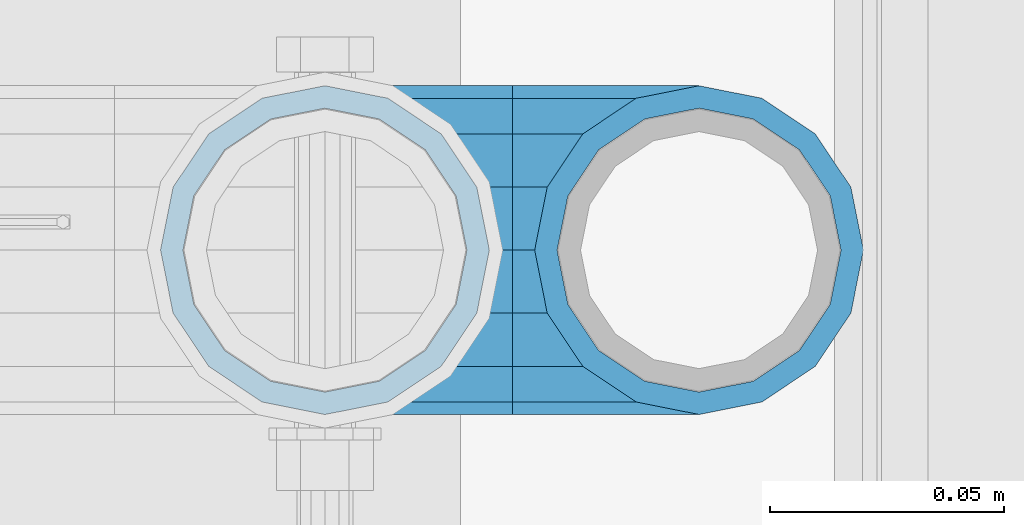
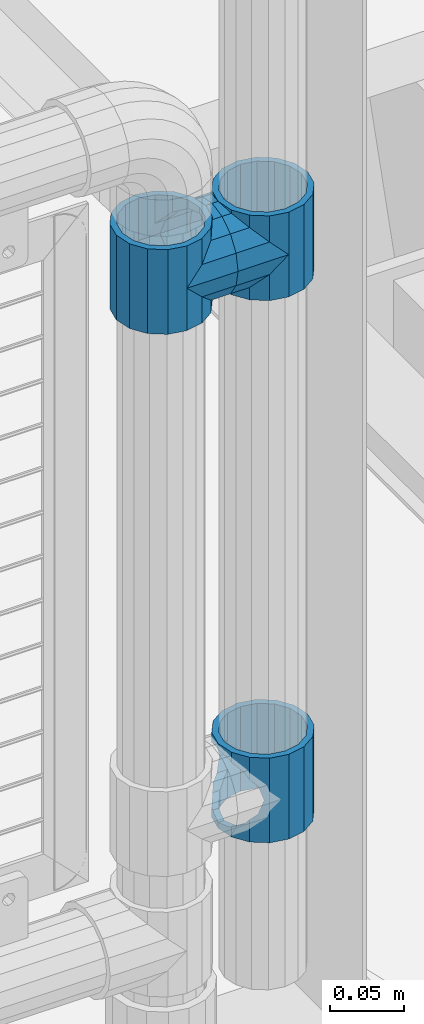
# One storey, part 163 of 240: 5 beams.
"""IFC2X3 building model written with IfcOpenShell, lengths in millimetres."""

from ifc_helpers import new_model, si_unit, frame, origin_with_axes, place, context, subcontext, project, spatial, faceted_brep, material, type_object, element, save


model = new_model("IFC2X3")

# Units and contexts
model_context = context("Model", 3, precision=1e-05, world=origin_with_axes())
body_context = subcontext(model_context, "Body", "Model", "MODEL_VIEW")
ifc_project = project(units=[si_unit("LENGTHUNIT", "METRE", prefix="MILLI"), si_unit("AREAUNIT", "SQUARE_METRE"), si_unit("VOLUMEUNIT", "CUBIC_METRE"), si_unit("MASSUNIT", "GRAM", prefix="KILO"), si_unit("TIMEUNIT", "SECOND"), si_unit("PLANEANGLEUNIT", "RADIAN"), si_unit("SOLIDANGLEUNIT", "STERADIAN"), si_unit("THERMODYNAMICTEMPERATUREUNIT", "DEGREE_CELSIUS"), si_unit("LUMINOUSINTENSITYUNIT", "LUMEN")], contexts=[model_context])

# Site, building, storey
site_placement = place(None, origin_with_axes())
site = spatial("IfcSite", under=ifc_project, at=site_placement, CompositionType="ELEMENT")
building_placement = place(site_placement, origin_with_axes())
building = spatial("IfcBuilding", under=site, at=building_placement, Name="Standard", CompositionType="ELEMENT")
storey_placement = place(building_placement, origin_with_axes())
storey = spatial("IfcBuildingStorey", under=building, at=storey_placement, Name="Undefined", CompositionType="ELEMENT", Elevation=0.0)

# Beams
ifc_material = material(Name="Misc_Undefined")
beam_type = type_object("IfcBeamType", PredefinedType="NOTDEFINED")
beam_1_placement = place(storey_placement, frame((55961.0, 34664.5, 433.819999999999), z_axis=(1.0, 0.0, 0.0), x_axis=(0.0, 0.0, -1.0)))
element("IfcBeam", 1, at=beam_1_placement, inside=storey, type_object=beam_type, material=ifc_material, context=body_context, shape_type="Brep", body=[
    faceted_brep([(46.7644421722801, 28.0397438117143, -11.6144421722784), (46.7644421722801, 28.0397438117143, -20.0882031229849), (51.5310424079941, 24.8548033587067, -24.8548033587067), (56.6106908090114, 21.4606908090136, -27.1226768591077), (56.6106908090114, 21.4606908090136, -21.4606908090136), (61.9623795176703, 13.4513226476338, -32.4743655677739), (63.1897438117172, 11.6144421722784, -32.8397438117172), (63.1897438117172, 11.6144421722784, -28.0397438117143), (65.4999999999997, 0.0, -35.1500000000015), (65.4999999999997, 0.0, -30.3499999999985), (63.1897438117172, -11.6144421722784, -32.8397438117245), (63.1897438117172, -11.6144421722784, -28.0397438117143), (61.9623795176703, -13.4513226476338, -32.4743655677739), (56.6106908090114, -21.4606908090136, -27.1226768591223), (56.6106908090114, -21.4606908090136, -21.4606908090136), (51.5310424080006, -24.8548033587067, -24.8548033587067), (46.7644421722801, -28.0397438117143, -20.0882031229994), (46.7644421722801, -28.0397438117143, -11.6144421722784), (35.1499999999996, -30.3499999999985, -16.6306603983758), (35.1500000000015, -30.35, 0.0), (23.5355578277191, -28.0397438117143, -20.0882031229994), (23.5355578277191, -28.0397438117143, -11.6144421722784), (18.7689575919987, -24.8548033587067, -24.8548033587067), (13.6893091909879, -21.4606908090136, -27.1226768591223), (13.6893091909879, -21.4606908090136, -21.4606908090136), (8.33762048232455, -13.4513226476338, -32.4743655677739), (7.11025618828211, -11.6144421722784, -32.8397438117245), (7.11025618828211, -11.6144421722784, -28.0397438117143), (4.79999999999961, 0.0, -35.1500000000015), (4.79999999999961, 0.0, -30.3499999999985), (7.11025618828211, 11.6144421722784, -32.8397438117172), (7.11025618828211, 11.6144421722784, -28.0397438117143), (8.33762048232893, 13.4513226476338, -32.4743655677739), (13.6893091909879, 21.4606908090136, -27.1226768591077), (13.6893091909879, 21.4606908090136, -21.4606908090136), (18.7689575919921, 24.8548033587067, -24.8548033587067), (23.5355578277192, 28.0397438117143, -20.0882031229849), (23.5355578277192, 28.0397438117143, -11.6144421722784), (35.1499999999996, 30.3499999999985, -16.6306603983685), (35.1500000000015, 30.35, 0.0), (0.0, 32.4743655677739, -13.4513226476338), (0.0, 35.1500000000015, 0.0), (70.2999999999993, 35.1500000000015, 0.0), (70.2999999999993, 32.4743655677739, -13.4513226476338), (0.0, 32.4743655677739, 13.4513226476338), (70.2999999999993, 32.4743655677739, 13.4513226476338), (0.0, 24.8548033587067, 24.8548033587067), (70.2999999999993, 24.8548033587067, 24.8548033587067), (0.0, 13.4513226476338, 32.4743655677739), (70.2999999999993, 13.4513226476338, 32.4743655677739), (0.0, 0.0, 35.1500000000015), (70.2999999999993, 0.0, 35.1500000000015), (0.0, -13.4513226476338, 32.4743655677739), (70.2999999999993, -13.4513226476338, 32.4743655677739), (0.0, -24.8548033587067, 24.8548033587067), (70.2999999999993, -24.8548033587067, 24.8548033587067), (0.0, -32.4743655677739, 13.4513226476338), (70.2999999999993, -32.4743655677739, 13.4513226476338), (0.0, -35.1500000000015, 0.0), (70.2999999999993, -35.1500000000015, 0.0), (70.2999999999993, -30.3499999999985, 0.0), (70.2999999999993, -28.0397438117143, -11.6144421722784), (70.2999999999993, -21.4606908090136, -21.4606908090136), (70.2999999999993, -11.6144421722784, -28.0397438117143), (70.2999999999993, 0.0, -30.3499999999985), (70.2999999999993, 11.6144421722784, -28.0397438117143), (70.2999999999993, 21.4606908090136, -21.4606908090136), (70.2999999999993, 28.0397438117143, -11.6144421722784), (0.0, -28.0397438117143, -11.6144421722784), (0.0, -30.3499999999985, 0.0), (0.0, -21.4606908090136, -21.4606908090136), (0.0, -11.6144421722784, -28.0397438117143), (0.0, 0.0, -30.3499999999985), (0.0, 11.6144421722784, -28.0397438117143), (0.0, 21.4606908090136, -21.4606908090136), (0.0, 28.0397438117143, -11.6144421722784), (0.0, 30.3499999999985, 0.0), (70.2999999999993, 30.3499999999985, 0.0), (0.0, 28.0397438117143, 11.6144421722784), (70.2999999999993, 28.0397438117143, 11.6144421722784), (0.0, 21.4606908090136, 21.4606908090136), (70.2999999999993, 21.4606908090136, 21.4606908090136), (0.0, 11.6144421722784, 28.0397438117143), (70.2999999999993, 11.6144421722784, 28.0397438117143), (0.0, 0.0, 30.3499999999985), (70.2999999999993, 0.0, 30.3499999999985), (0.0, -11.6144421722784, 28.0397438117143), (70.2999999999993, -11.6144421722784, 28.0397438117143), (0.0, -21.4606908090136, 21.4606908090136), (70.2999999999993, -21.4606908090136, 21.4606908090136), (0.0, -28.0397438117143, 11.6144421722784), (70.2999999999993, -28.0397438117143, 11.6144421722784), (70.2999999999993, -24.8548033587067, -24.8548033587067), (70.2999999999993, -13.4513226476338, -32.4743655677739), (70.2999999999993, 0.0, -35.1500000000015), (70.2999999999993, 13.4513226476338, -32.4743655677739), (70.2999999999993, 24.8548033587067, -24.8548033587067), (70.2999999999993, -32.4743655677739, -13.4513226476338), (0.0, -32.4743655677739, -13.4513226476338), (0.0, 24.8548033587067, -24.8548033587067), (0.0, 13.4513226476338, -32.4743655677739), (0.0, 0.0, -35.1500000000015), (0.0, -13.4513226476338, -32.4743655677739), (0.0, -24.8548033587067, -24.8548033587067)], [[[0, 1, 2, 3, 4]], [[4, 3, 5, 6, 7]], [[7, 6, 8, 9]], [[9, 8, 10, 11]], [[11, 10, 12, 13, 14]], [[14, 13, 15, 16, 17]], [[17, 16, 18, 19]], [[19, 18, 20, 21]], [[21, 20, 22, 23, 24]], [[24, 23, 25, 26, 27]], [[27, 26, 28, 29]], [[29, 28, 30, 31]], [[31, 30, 32, 33, 34]], [[34, 33, 35, 36, 37]], [[37, 36, 38, 39]], [[39, 38, 1, 0]], [[40, 41, 42, 43]], [[41, 44, 45, 42]], [[44, 46, 47, 45]], [[46, 48, 49, 47]], [[48, 50, 51, 49]], [[50, 52, 53, 51]], [[52, 54, 55, 53]], [[54, 56, 57, 55]], [[56, 58, 59, 57]], [[60, 61, 17, 19]], [[61, 62, 14, 17]], [[62, 63, 11, 14]], [[63, 64, 9, 11]], [[64, 65, 7, 9]], [[65, 66, 4, 7]], [[66, 67, 0, 4]], [[68, 69, 19, 21]], [[70, 68, 21, 24]], [[71, 70, 24, 27]], [[72, 71, 27, 29]], [[73, 72, 29, 31]], [[74, 73, 31, 34]], [[75, 74, 34, 37]], [[76, 75, 37, 39]], [[67, 77, 39, 0]], [[78, 76, 39, 77, 79]], [[80, 78, 79, 81]], [[82, 80, 81, 83]], [[84, 82, 83, 85]], [[86, 84, 85, 87]], [[88, 86, 87, 89]], [[90, 88, 89, 91]], [[19, 69, 90, 91, 60]], [[92, 93, 94, 95, 96, 43, 42, 45, 47, 49, 51, 53, 55, 57, 59, 97], [89, 87, 85, 83, 81, 79, 77, 67, 66, 65, 64, 63, 62, 61, 60, 91]], [[58, 98, 97, 59]], [[56, 54, 52, 50, 48, 46, 44, 41, 40, 99, 100, 101, 102, 103, 98, 58], [68, 70, 71, 72, 73, 74, 75, 76, 78, 80, 82, 84, 86, 88, 90, 69]], [[32, 100, 99, 35, 33]], [[28, 101, 100, 32, 30]], [[102, 101, 28, 26, 25]], [[103, 102, 25, 23, 22]], [[15, 92, 97, 98, 103, 22, 20, 18, 16]], [[12, 93, 92, 15, 13]], [[8, 94, 93, 12, 10]], [[95, 94, 8, 6, 5]], [[96, 95, 5, 3, 2]], [[35, 99, 40, 43, 96, 2, 1, 38, 36]]]),
])
beam_2_placement = place(storey_placement, frame((55881.0, 34664.5, 848.669999999998), z_axis=(0.0, -1.0, 0.0), x_axis=(1.0, 0.0, 0.0)))
element("IfcBeam", 2, at=beam_2_placement, inside=storey, type_object=beam_type, material=ifc_material, context=body_context, shape_type="Brep", body=[
    faceted_brep([(0.0, 0.0, -35.1500000000015), (13.4513226476338, -13.4513226476329, -32.4743655677739), (13.4513226476338, 13.4513226476329, -32.4743655677739), (32.4743655677739, 32.4743655677717, 13.4513226476338), (32.4743655677739, 26.8123795176755, 13.4513226476338), (27.1226768591005, 21.4606908090117, 21.4606908090136), (24.8548033587067, 16.3810424080013, 24.8548033587067), (24.8548033587067, 24.8548033587072, 24.8548033587067), (0.0, 0.0, 35.1500000000015), (13.4513226476338, 13.4513226476329, 32.4743655677739), (13.4513226476338, -13.4513226476329, 32.4743655677739), (20.0882031229849, 11.6144421722805, 28.0397438117143), (16.6306603983685, 0.0, 30.3499999999985), (20.0882031229849, -11.6144421722805, 28.0397438117143), (24.8548033587067, -16.3810424080078, 24.8548033587067), (24.8548033587067, -24.8548033587072, 24.8548033587067), (27.1226768591005, -21.4606908090117, 21.4606908090136), (32.4743655677739, -26.8123795176712, 13.4513226476338), (32.4743655677739, -32.4743655677717, 13.4513226476338), (32.8397438117099, -28.0397438117175, 11.6144421722784), (35.1500000000015, -30.35, 0.0), (35.1500000000015, -35.15, 0.0), (32.4743655677739, -26.8123795176712, -13.4513226476338), (32.4743655677739, -32.4743655677717, -13.4513226476338), (32.8397438117172, -28.0397438117175, -11.6144421722784), (24.8548033587067, -16.3810424079947, -24.8548033587067), (24.8548033587067, -24.8548033587072, -24.8548033587067), (27.1226768591223, -21.4606908090117, -21.4606908090136), (20.0882031229994, -11.6144421722805, -28.0397438117143), (16.6306603983758, 0.0, -30.3499999999985), (20.0882031229994, 11.6144421722805, -28.0397438117143), (24.8548033587067, 16.3810424080013, -24.8548033587067), (24.8548033587067, 24.8548033587072, -24.8548033587067), (27.1226768591223, 21.4606908090117, -21.4606908090136), (32.4743655677739, 26.8123795176712, -13.4513226476338), (32.4743655677739, 32.4743655677717, -13.4513226476338), (32.8397438117172, 28.0397438117175, -11.6144421722784), (35.1500000000015, 30.35, 0.0), (35.1500000000015, 35.15, 0.0), (32.8397438117099, 28.0397438117175, 11.6144421722784), (40.1500000000015, -35.15, 0.0), (40.1500000000015, -32.4743655677717, 13.4513226476338), (40.1500000000015, -24.8548033587072, 24.8548033587067), (40.1500000000015, -13.4513226476329, 32.4743655677739), (40.1500000000015, 0.0, 35.1500000000015), (40.1500000000015, 13.4513226476329, 32.4743655677739), (40.1500000000015, 24.8548033587072, 24.8548033587067), (40.1500000000015, 32.4743655677717, 13.4513226476338), (40.1500000000015, 35.15, 0.0), (40.1500000000015, -24.8548033587072, -24.8548033587067), (40.1500000000015, -32.4743655677717, -13.4513226476338), (40.1500000000015, -13.4513226476329, -32.4743655677739), (40.1500000000015, 0.0, -35.1500000000015), (40.1500000000015, 13.4513226476329, -32.4743655677739), (40.1500000000015, 24.8548033587072, -24.8548033587067), (40.1500000000015, 32.4743655677717, -13.4513226476338), (40.1500000000015, -21.4606908090117, 21.4606908090136), (40.1500000000015, -11.6144421722805, 28.0397438117143), (40.1500000000015, 0.0, 30.3499999999985), (40.1500000000015, 11.6144421722805, 28.0397438117143), (40.1500000000015, 21.4606908090117, 21.4606908090136), (40.1500000000015, 28.0397438117175, 11.6144421722784), (40.1500000000015, 30.35, 0.0), (40.1500000000015, 28.0397438117175, -11.6144421722784), (40.1500000000015, 21.4606908090117, -21.4606908090136), (40.1500000000015, 11.6144421722805, -28.0397438117143), (40.1500000000015, 0.0, -30.3499999999985), (40.1500000000015, -11.6144421722805, -28.0397438117143), (40.1500000000015, -21.4606908090117, -21.4606908090136), (40.1500000000015, -28.0397438117175, -11.6144421722784), (40.1500000000015, -30.35, 0.0), (40.1500000000015, -28.0397438117175, 11.6144421722784)], [[[0, 1, 2]], [[3, 4, 5, 6, 7]], [[8, 9, 10]], [[7, 6, 11, 12, 13, 14, 15, 10, 9]], [[16, 17, 18, 15, 14]], [[19, 20, 21, 18, 17]], [[22, 23, 21, 20, 24]], [[25, 26, 23, 22, 27]], [[2, 1, 26, 25, 28, 29, 30, 31, 32]], [[32, 31, 33, 34, 35]], [[35, 34, 36, 37, 38]], [[38, 37, 39, 4, 3]], [[40, 41, 18, 21]], [[41, 42, 15, 18]], [[42, 43, 10, 15]], [[43, 44, 8, 10]], [[44, 45, 9, 8]], [[45, 46, 7, 9]], [[46, 47, 3, 7]], [[47, 48, 38, 3]], [[49, 50, 23, 26]], [[51, 49, 26, 1]], [[52, 51, 1, 0]], [[53, 52, 0, 2]], [[54, 53, 2, 32]], [[55, 54, 32, 35]], [[48, 55, 35, 38]], [[50, 40, 21, 23]], [[49, 51, 52, 53, 54, 55, 48, 47, 46, 45, 44, 43, 42, 41, 40, 50], [56, 57, 58, 59, 60, 61, 62, 63, 64, 65, 66, 67, 68, 69, 70, 71]], [[63, 62, 37, 36]], [[33, 64, 63, 36, 34]], [[30, 65, 64, 33, 31]], [[66, 65, 30, 29]], [[67, 66, 29, 28]], [[68, 67, 28, 25, 27]], [[69, 68, 27, 22, 24]], [[70, 69, 24, 20]], [[71, 70, 20, 19]], [[16, 56, 71, 19, 17]], [[13, 57, 56, 16, 14]], [[58, 57, 13, 12]], [[59, 58, 12, 11]], [[60, 59, 11, 6, 5]], [[61, 60, 5, 4, 39]], [[62, 61, 39, 37]]]),
])
beam_3_placement = place(storey_placement, frame((55961.0, 34664.5, 848.669999999998), z_axis=(0.0, 1.0, 0.0), x_axis=(-1.0, 0.0, 0.0)))
element("IfcBeam", 3, at=beam_3_placement, inside=storey, type_object=beam_type, material=ifc_material, context=body_context, shape_type="Brep", body=[
    faceted_brep([(0.0, 0.0, -35.1500000000015), (13.4513226476338, -13.4513226476329, -32.4743655677739), (13.4513226476338, 13.4513226476329, -32.4743655677739), (27.1226768591005, -21.4606908090117, 21.4606908090136), (32.4743655677739, -26.8123795176712, 13.4513226476338), (32.4743655677739, -32.4743655677717, 13.4513226476338), (24.8548033587067, -24.8548033587072, 24.8548033587067), (24.8548033587067, -16.3810424080078, 24.8548033587067), (32.8397438117099, -28.0397438117175, 11.6144421722784), (35.1500000000015, -30.35, 0.0), (35.1500000000015, -35.15, 0.0), (32.4743655677739, -26.8123795176712, -13.4513226476338), (32.4743655677739, -32.4743655677717, -13.4513226476338), (32.8397438117172, -28.0397438117175, -11.6144421722784), (24.8548033587067, -16.3810424079947, -24.8548033587067), (24.8548033587067, -24.8548033587072, -24.8548033587067), (27.1226768591223, -21.4606908090117, -21.4606908090136), (20.0882031229994, -11.6144421722805, -28.0397438117143), (16.6306603983758, 0.0, -30.3499999999985), (20.0882031229994, 11.6144421722805, -28.0397438117143), (24.8548033587067, 16.3810424080013, -24.8548033587067), (24.8548033587067, 24.8548033587072, -24.8548033587067), (27.1226768591223, 21.4606908090117, -21.4606908090136), (32.4743655677739, 26.8123795176712, -13.4513226476338), (32.4743655677739, 32.4743655677717, -13.4513226476338), (32.8397438117172, 28.0397438117175, -11.6144421722784), (35.1500000000015, 30.35, 0.0), (35.1500000000015, 35.15, 0.0), (32.8397438117099, 28.0397438117175, 11.6144421722784), (32.4743655677739, 26.8123795176755, 13.4513226476338), (32.4743655677739, 32.4743655677717, 13.4513226476338), (27.1226768591005, 21.4606908090117, 21.4606908090136), (24.8548033587067, 16.3810424080013, 24.8548033587067), (24.8548033587067, 24.8548033587072, 24.8548033587067), (0.0, 0.0, 35.1500000000015), (13.4513226476338, 13.4513226476329, 32.4743655677739), (13.4513226476338, -13.4513226476329, 32.4743655677739), (20.0882031229849, 11.6144421722805, 28.0397438117143), (16.6306603983685, 0.0, 30.3499999999985), (20.0882031229849, -11.6144421722805, 28.0397438117143), (40.1500000000015, -35.15, 0.0), (40.1500000000015, -32.4743655677717, 13.4513226476338), (40.1500000000015, -24.8548033587072, 24.8548033587067), (40.1500000000015, -13.4513226476329, 32.4743655677739), (40.1500000000015, 0.0, 35.1500000000015), (40.1500000000015, -24.8548033587072, -24.8548033587067), (40.1500000000015, -32.4743655677717, -13.4513226476338), (40.1500000000015, -13.4513226476329, -32.4743655677739), (40.1500000000015, 0.0, -35.1500000000015), (40.1500000000015, 13.4513226476329, -32.4743655677739), (40.1500000000015, 24.8548033587072, -24.8548033587067), (40.1500000000015, 32.4743655677717, -13.4513226476338), (40.1500000000015, 35.15, 0.0), (40.1500000000015, 32.4743655677717, 13.4513226476338), (40.1500000000015, 24.8548033587072, 24.8548033587067), (40.1500000000015, 13.4513226476329, 32.4743655677739), (40.1500000000015, -21.4606908090117, 21.4606908090136), (40.1500000000015, -11.6144421722805, 28.0397438117143), (40.1500000000015, 0.0, 30.3499999999985), (40.1500000000015, 11.6144421722805, 28.0397438117143), (40.1500000000015, 21.4606908090117, 21.4606908090136), (40.1500000000015, 28.0397438117175, 11.6144421722784), (40.1500000000015, 30.35, 0.0), (40.1500000000015, 28.0397438117175, -11.6144421722784), (40.1500000000015, 21.4606908090117, -21.4606908090136), (40.1500000000015, 11.6144421722805, -28.0397438117143), (40.1500000000015, 0.0, -30.3499999999985), (40.1500000000015, -11.6144421722805, -28.0397438117143), (40.1500000000015, -21.4606908090117, -21.4606908090136), (40.1500000000015, -28.0397438117175, -11.6144421722784), (40.1500000000015, -30.35, 0.0), (40.1500000000015, -28.0397438117175, 11.6144421722784)], [[[0, 1, 2]], [[3, 4, 5, 6, 7]], [[8, 9, 10, 5, 4]], [[11, 12, 10, 9, 13]], [[14, 15, 12, 11, 16]], [[2, 1, 15, 14, 17, 18, 19, 20, 21]], [[21, 20, 22, 23, 24]], [[24, 23, 25, 26, 27]], [[27, 26, 28, 29, 30]], [[30, 29, 31, 32, 33]], [[34, 35, 36]], [[33, 32, 37, 38, 39, 7, 6, 36, 35]], [[40, 41, 5, 10]], [[41, 42, 6, 5]], [[42, 43, 36, 6]], [[43, 44, 34, 36]], [[45, 46, 12, 15]], [[47, 45, 15, 1]], [[48, 47, 1, 0]], [[49, 48, 0, 2]], [[50, 49, 2, 21]], [[51, 50, 21, 24]], [[52, 51, 24, 27]], [[53, 52, 27, 30]], [[54, 53, 30, 33]], [[55, 54, 33, 35]], [[44, 55, 35, 34]], [[46, 40, 10, 12]], [[45, 47, 48, 49, 50, 51, 52, 53, 54, 55, 44, 43, 42, 41, 40, 46], [56, 57, 58, 59, 60, 61, 62, 63, 64, 65, 66, 67, 68, 69, 70, 71]], [[59, 58, 38, 37]], [[60, 59, 37, 32, 31]], [[61, 60, 31, 29, 28]], [[62, 61, 28, 26]], [[63, 62, 26, 25]], [[22, 64, 63, 25, 23]], [[19, 65, 64, 22, 20]], [[66, 65, 19, 18]], [[67, 66, 18, 17]], [[68, 67, 17, 14, 16]], [[69, 68, 16, 11, 13]], [[70, 69, 13, 9]], [[71, 70, 9, 8]], [[3, 56, 71, 8, 4]], [[39, 57, 56, 3, 7]], [[58, 57, 39, 38]]]),
])
beam_4_placement = place(storey_placement, frame((55881.0, 34664.5, 883.819999999998), z_axis=(-1.0, 0.0, 0.0), x_axis=(0.0, 0.0, -1.0)))
element("IfcBeam", 4, at=beam_4_placement, inside=storey, type_object=beam_type, material=ifc_material, context=body_context, shape_type="Brep", body=[
    faceted_brep([(13.6893091909879, -21.4606908090136, -21.4606908090136), (13.6893091909879, -21.4606908090136, -27.1226768591223), (8.33762048232455, -13.4513226476338, -32.4743655677739), (7.11025618828211, -11.6144421722784, -32.8397438117245), (7.11025618828211, -11.6144421722784, -28.0397438117143), (23.5355578277191, -28.0397438117143, -11.6144421722784), (23.5355578277191, -28.0397438117143, -20.0882031229994), (18.7689575919987, -24.8548033587067, -24.8548033587067), (35.1500000000015, -30.35, 0.0), (35.1499999999996, -30.3499999999985, -16.6306603983758), (46.7644421722801, -28.0397438117143, -11.6144421722784), (46.7644421722801, -28.0397438117143, -20.0882031229994), (56.6106908090114, -21.4606908090136, -21.4606908090136), (56.6106908090114, -21.4606908090136, -27.1226768591223), (51.5310424080006, -24.8548033587067, -24.8548033587067), (63.1897438117172, -11.6144421722784, -28.0397438117143), (63.1897438117172, -11.6144421722784, -32.8397438117245), (61.9623795176703, -13.4513226476338, -32.4743655677739), (65.4999999999997, 0.0, -30.3499999999985), (65.4999999999997, 0.0, -35.1500000000015), (63.1897438117172, 11.6144421722784, -28.0397438117143), (63.1897438117172, 11.6144421722784, -32.8397438117172), (56.6106908090114, 21.4606908090136, -21.4606908090136), (56.6106908090114, 21.4606908090136, -27.1226768591077), (61.9623795176703, 13.4513226476338, -32.4743655677739), (46.7644421722801, 28.0397438117143, -11.6144421722784), (46.7644421722801, 28.0397438117143, -20.0882031229849), (51.5310424079941, 24.8548033587067, -24.8548033587067), (35.1500000000015, 30.35, 0.0), (35.1499999999996, 30.3499999999985, -16.6306603983685), (23.5355578277192, 28.0397438117143, -11.6144421722784), (23.5355578277192, 28.0397438117143, -20.0882031229849), (13.6893091909879, 21.4606908090136, -21.4606908090136), (13.6893091909879, 21.4606908090136, -27.1226768591077), (18.7689575919921, 24.8548033587067, -24.8548033587067), (7.11025618828211, 11.6144421722784, -28.0397438117143), (7.11025618828211, 11.6144421722784, -32.8397438117172), (8.33762048232893, 13.4513226476338, -32.4743655677739), (4.79999999999961, 0.0, -30.3499999999985), (4.79999999999961, 0.0, -35.1500000000015), (0.0, 21.4606908090136, 21.4606908090136), (0.0, 28.0397438117143, 11.6144421722784), (70.2999999999993, 28.0397438117143, 11.6144421722784), (70.2999999999993, 21.4606908090136, 21.4606908090136), (0.0, 11.6144421722784, 28.0397438117143), (70.2999999999993, 11.6144421722784, 28.0397438117143), (0.0, 0.0, 30.3499999999985), (70.2999999999993, 0.0, 30.3499999999985), (0.0, -11.6144421722784, 28.0397438117143), (70.2999999999993, -11.6144421722784, 28.0397438117143), (0.0, -21.4606908090136, 21.4606908090136), (70.2999999999993, -21.4606908090136, 21.4606908090136), (0.0, -28.0397438117143, 11.6144421722784), (70.2999999999993, -28.0397438117143, 11.6144421722784), (0.0, -24.8548033587067, -24.8548033587067), (0.0, -13.4513226476338, -32.4743655677739), (0.0, 0.0, -35.1500000000015), (0.0, -32.4743655677739, 13.4513226476338), (0.0, -35.1500000000015, 0.0), (70.2999999999993, -35.1500000000015, 0.0), (70.2999999999993, -32.4743655677739, 13.4513226476338), (0.0, -24.8548033587067, 24.8548033587067), (70.2999999999993, -24.8548033587067, 24.8548033587067), (0.0, -13.4513226476338, 32.4743655677739), (70.2999999999993, -13.4513226476338, 32.4743655677739), (0.0, 0.0, 35.1500000000015), (70.2999999999993, 0.0, 35.1500000000015), (0.0, 13.4513226476338, 32.4743655677739), (70.2999999999993, 13.4513226476338, 32.4743655677739), (0.0, 24.8548033587067, 24.8548033587067), (70.2999999999993, 24.8548033587067, 24.8548033587067), (0.0, 32.4743655677739, 13.4513226476338), (70.2999999999993, 32.4743655677739, 13.4513226476338), (0.0, 35.1500000000015, 0.0), (70.2999999999993, 35.1500000000015, 0.0), (0.0, 32.4743655677739, -13.4513226476338), (70.2999999999993, 32.4743655677739, -13.4513226476338), (70.2999999999993, -13.4513226476338, -32.4743655677739), (70.2999999999993, -24.8548033587067, -24.8548033587067), (70.2999999999993, 0.0, -35.1500000000015), (70.2999999999993, 13.4513226476338, -32.4743655677739), (70.2999999999993, 24.8548033587067, -24.8548033587067), (0.0, 24.8548033587067, -24.8548033587067), (0.0, 13.4513226476338, -32.4743655677739), (70.2999999999993, -32.4743655677739, -13.4513226476338), (0.0, -32.4743655677739, -13.4513226476338), (0.0, -28.0397438117143, -11.6144421722784), (0.0, -21.4606908090136, -21.4606908090136), (0.0, -11.6144421722784, -28.0397438117143), (0.0, 0.0, -30.3499999999985), (0.0, 11.6144421722784, -28.0397438117143), (0.0, 21.4606908090136, -21.4606908090136), (0.0, 28.0397438117143, -11.6144421722784), (0.0, 30.3499999999985, 0.0), (0.0, -30.3499999999985, 0.0), (70.2999999999993, 30.3499999999985, 0.0), (70.2999999999993, 28.0397438117143, -11.6144421722784), (70.2999999999993, 21.4606908090136, -21.4606908090136), (70.2999999999993, 11.6144421722784, -28.0397438117143), (70.2999999999993, 0.0, -30.3499999999985), (70.2999999999993, -11.6144421722784, -28.0397438117143), (70.2999999999993, -21.4606908090136, -21.4606908090136), (70.2999999999993, -28.0397438117143, -11.6144421722784), (70.2999999999993, -30.3499999999985, 0.0)], [[[0, 1, 2, 3, 4]], [[5, 6, 7, 1, 0]], [[8, 9, 6, 5]], [[10, 11, 9, 8]], [[12, 13, 14, 11, 10]], [[15, 16, 17, 13, 12]], [[18, 19, 16, 15]], [[20, 21, 19, 18]], [[22, 23, 24, 21, 20]], [[25, 26, 27, 23, 22]], [[28, 29, 26, 25]], [[30, 31, 29, 28]], [[32, 33, 34, 31, 30]], [[35, 36, 37, 33, 32]], [[38, 39, 36, 35]], [[4, 3, 39, 38]], [[40, 41, 42, 43]], [[44, 40, 43, 45]], [[46, 44, 45, 47]], [[48, 46, 47, 49]], [[50, 48, 49, 51]], [[52, 50, 51, 53]], [[54, 55, 2, 1, 7]], [[55, 56, 39, 3, 2]], [[57, 58, 59, 60]], [[61, 57, 60, 62]], [[63, 61, 62, 64]], [[65, 63, 64, 66]], [[67, 65, 66, 68]], [[69, 67, 68, 70]], [[71, 69, 70, 72]], [[73, 71, 72, 74]], [[75, 73, 74, 76]], [[17, 77, 78, 14, 13]], [[19, 79, 77, 17, 16]], [[80, 79, 19, 21, 24]], [[81, 80, 24, 23, 27]], [[34, 82, 75, 76, 81, 27, 26, 29, 31]], [[37, 83, 82, 34, 33]], [[39, 56, 83, 37, 36]], [[14, 78, 84, 85, 54, 7, 6, 9, 11]], [[58, 85, 84, 59]], [[57, 61, 63, 65, 67, 69, 71, 73, 75, 82, 83, 56, 55, 54, 85, 58], [86, 87, 88, 89, 90, 91, 92, 93, 41, 40, 44, 46, 48, 50, 52, 94]], [[90, 89, 38, 35]], [[91, 90, 35, 32]], [[92, 91, 32, 30]], [[93, 92, 30, 28]], [[41, 93, 28, 95, 42]], [[96, 95, 28, 25]], [[97, 96, 25, 22]], [[98, 97, 22, 20]], [[99, 98, 20, 18]], [[100, 99, 18, 15]], [[101, 100, 15, 12]], [[102, 101, 12, 10]], [[103, 102, 10, 8]], [[78, 77, 79, 80, 81, 76, 74, 72, 70, 68, 66, 64, 62, 60, 59, 84], [51, 49, 47, 45, 43, 42, 95, 96, 97, 98, 99, 100, 101, 102, 103, 53]], [[8, 94, 52, 53, 103]], [[86, 94, 8, 5]], [[87, 86, 5, 0]], [[88, 87, 0, 4]], [[89, 88, 4, 38]]]),
])
beam_5_placement = place(storey_placement, frame((55961.0, 34664.5, 883.819999999998), z_axis=(1.0, 0.0, 0.0), x_axis=(0.0, 0.0, -1.0)))
element("IfcBeam", 5, at=beam_5_placement, inside=storey, type_object=beam_type, material=ifc_material, context=body_context, shape_type="Brep", body=[
    faceted_brep([(46.7644421722801, 28.0397438117143, -11.6144421722784), (46.7644421722801, 28.0397438117143, -20.0882031229849), (51.5310424079941, 24.8548033587067, -24.8548033587067), (56.6106908090114, 21.4606908090136, -27.1226768591077), (56.6106908090114, 21.4606908090136, -21.4606908090136), (61.9623795176703, 13.4513226476338, -32.4743655677739), (63.1897438117172, 11.6144421722784, -32.8397438117172), (63.1897438117172, 11.6144421722784, -28.0397438117143), (65.4999999999997, 0.0, -35.1500000000015), (65.4999999999997, 0.0, -30.3499999999985), (63.1897438117172, -11.6144421722784, -32.8397438117245), (63.1897438117172, -11.6144421722784, -28.0397438117143), (61.9623795176703, -13.4513226476338, -32.4743655677739), (56.6106908090114, -21.4606908090136, -27.1226768591223), (56.6106908090114, -21.4606908090136, -21.4606908090136), (51.5310424080006, -24.8548033587067, -24.8548033587067), (46.7644421722801, -28.0397438117143, -20.0882031229994), (46.7644421722801, -28.0397438117143, -11.6144421722784), (35.1499999999996, -30.3499999999985, -16.6306603983758), (35.1500000000015, -30.35, 0.0), (23.5355578277191, -28.0397438117143, -20.0882031229994), (23.5355578277191, -28.0397438117143, -11.6144421722784), (18.7689575919987, -24.8548033587067, -24.8548033587067), (13.6893091909879, -21.4606908090136, -27.1226768591223), (13.6893091909879, -21.4606908090136, -21.4606908090136), (8.33762048232455, -13.4513226476338, -32.4743655677739), (7.11025618828211, -11.6144421722784, -32.8397438117245), (7.11025618828211, -11.6144421722784, -28.0397438117143), (4.79999999999961, 0.0, -35.1500000000015), (4.79999999999961, 0.0, -30.3499999999985), (7.11025618828211, 11.6144421722784, -32.8397438117172), (7.11025618828211, 11.6144421722784, -28.0397438117143), (8.33762048232893, 13.4513226476338, -32.4743655677739), (13.6893091909879, 21.4606908090136, -27.1226768591077), (13.6893091909879, 21.4606908090136, -21.4606908090136), (18.7689575919921, 24.8548033587067, -24.8548033587067), (23.5355578277192, 28.0397438117143, -20.0882031229849), (23.5355578277192, 28.0397438117143, -11.6144421722784), (35.1499999999996, 30.3499999999985, -16.6306603983685), (35.1500000000015, 30.35, 0.0), (0.0, 32.4743655677739, -13.4513226476338), (0.0, 35.1500000000015, 0.0), (70.2999999999993, 35.1500000000015, 0.0), (70.2999999999993, 32.4743655677739, -13.4513226476338), (0.0, 32.4743655677739, 13.4513226476338), (70.2999999999993, 32.4743655677739, 13.4513226476338), (0.0, 24.8548033587067, 24.8548033587067), (70.2999999999993, 24.8548033587067, 24.8548033587067), (0.0, 13.4513226476338, 32.4743655677739), (70.2999999999993, 13.4513226476338, 32.4743655677739), (0.0, 0.0, 35.1500000000015), (70.2999999999993, 0.0, 35.1500000000015), (0.0, -13.4513226476338, 32.4743655677739), (70.2999999999993, -13.4513226476338, 32.4743655677739), (0.0, -24.8548033587067, 24.8548033587067), (70.2999999999993, -24.8548033587067, 24.8548033587067), (0.0, -32.4743655677739, 13.4513226476338), (70.2999999999993, -32.4743655677739, 13.4513226476338), (0.0, -35.1500000000015, 0.0), (70.2999999999993, -35.1500000000015, 0.0), (70.2999999999993, -30.3499999999985, 0.0), (70.2999999999993, -28.0397438117143, -11.6144421722784), (70.2999999999993, -21.4606908090136, -21.4606908090136), (70.2999999999993, -11.6144421722784, -28.0397438117143), (70.2999999999993, 0.0, -30.3499999999985), (70.2999999999993, 11.6144421722784, -28.0397438117143), (70.2999999999993, 21.4606908090136, -21.4606908090136), (70.2999999999993, 28.0397438117143, -11.6144421722784), (0.0, -28.0397438117143, -11.6144421722784), (0.0, -30.3499999999985, 0.0), (0.0, -21.4606908090136, -21.4606908090136), (0.0, -11.6144421722784, -28.0397438117143), (0.0, 0.0, -30.3499999999985), (0.0, 11.6144421722784, -28.0397438117143), (0.0, 21.4606908090136, -21.4606908090136), (0.0, 28.0397438117143, -11.6144421722784), (0.0, 30.3499999999985, 0.0), (70.2999999999993, 30.3499999999985, 0.0), (0.0, 28.0397438117143, 11.6144421722784), (70.2999999999993, 28.0397438117143, 11.6144421722784), (0.0, 21.4606908090136, 21.4606908090136), (70.2999999999993, 21.4606908090136, 21.4606908090136), (0.0, 11.6144421722784, 28.0397438117143), (70.2999999999993, 11.6144421722784, 28.0397438117143), (0.0, 0.0, 30.3499999999985), (70.2999999999993, 0.0, 30.3499999999985), (0.0, -11.6144421722784, 28.0397438117143), (70.2999999999993, -11.6144421722784, 28.0397438117143), (0.0, -21.4606908090136, 21.4606908090136), (70.2999999999993, -21.4606908090136, 21.4606908090136), (0.0, -28.0397438117143, 11.6144421722784), (70.2999999999993, -28.0397438117143, 11.6144421722784), (70.2999999999993, -24.8548033587067, -24.8548033587067), (70.2999999999993, -13.4513226476338, -32.4743655677739), (70.2999999999993, 0.0, -35.1500000000015), (70.2999999999993, 13.4513226476338, -32.4743655677739), (70.2999999999993, 24.8548033587067, -24.8548033587067), (70.2999999999993, -32.4743655677739, -13.4513226476338), (0.0, -32.4743655677739, -13.4513226476338), (0.0, 24.8548033587067, -24.8548033587067), (0.0, 13.4513226476338, -32.4743655677739), (0.0, 0.0, -35.1500000000015), (0.0, -13.4513226476338, -32.4743655677739), (0.0, -24.8548033587067, -24.8548033587067)], [[[0, 1, 2, 3, 4]], [[4, 3, 5, 6, 7]], [[7, 6, 8, 9]], [[9, 8, 10, 11]], [[11, 10, 12, 13, 14]], [[14, 13, 15, 16, 17]], [[17, 16, 18, 19]], [[19, 18, 20, 21]], [[21, 20, 22, 23, 24]], [[24, 23, 25, 26, 27]], [[27, 26, 28, 29]], [[29, 28, 30, 31]], [[31, 30, 32, 33, 34]], [[34, 33, 35, 36, 37]], [[37, 36, 38, 39]], [[39, 38, 1, 0]], [[40, 41, 42, 43]], [[41, 44, 45, 42]], [[44, 46, 47, 45]], [[46, 48, 49, 47]], [[48, 50, 51, 49]], [[50, 52, 53, 51]], [[52, 54, 55, 53]], [[54, 56, 57, 55]], [[56, 58, 59, 57]], [[60, 61, 17, 19]], [[61, 62, 14, 17]], [[62, 63, 11, 14]], [[63, 64, 9, 11]], [[64, 65, 7, 9]], [[65, 66, 4, 7]], [[66, 67, 0, 4]], [[68, 69, 19, 21]], [[70, 68, 21, 24]], [[71, 70, 24, 27]], [[72, 71, 27, 29]], [[73, 72, 29, 31]], [[74, 73, 31, 34]], [[75, 74, 34, 37]], [[76, 75, 37, 39]], [[67, 77, 39, 0]], [[78, 76, 39, 77, 79]], [[80, 78, 79, 81]], [[82, 80, 81, 83]], [[84, 82, 83, 85]], [[86, 84, 85, 87]], [[88, 86, 87, 89]], [[90, 88, 89, 91]], [[19, 69, 90, 91, 60]], [[92, 93, 94, 95, 96, 43, 42, 45, 47, 49, 51, 53, 55, 57, 59, 97], [89, 87, 85, 83, 81, 79, 77, 67, 66, 65, 64, 63, 62, 61, 60, 91]], [[58, 98, 97, 59]], [[56, 54, 52, 50, 48, 46, 44, 41, 40, 99, 100, 101, 102, 103, 98, 58], [68, 70, 71, 72, 73, 74, 75, 76, 78, 80, 82, 84, 86, 88, 90, 69]], [[32, 100, 99, 35, 33]], [[28, 101, 100, 32, 30]], [[102, 101, 28, 26, 25]], [[103, 102, 25, 23, 22]], [[15, 92, 97, 98, 103, 22, 20, 18, 16]], [[12, 93, 92, 15, 13]], [[8, 94, 93, 12, 10]], [[95, 94, 8, 6, 5]], [[96, 95, 5, 3, 2]], [[35, 99, 40, 43, 96, 2, 1, 38, 36]]]),
])

save(model, "model.ifc")
